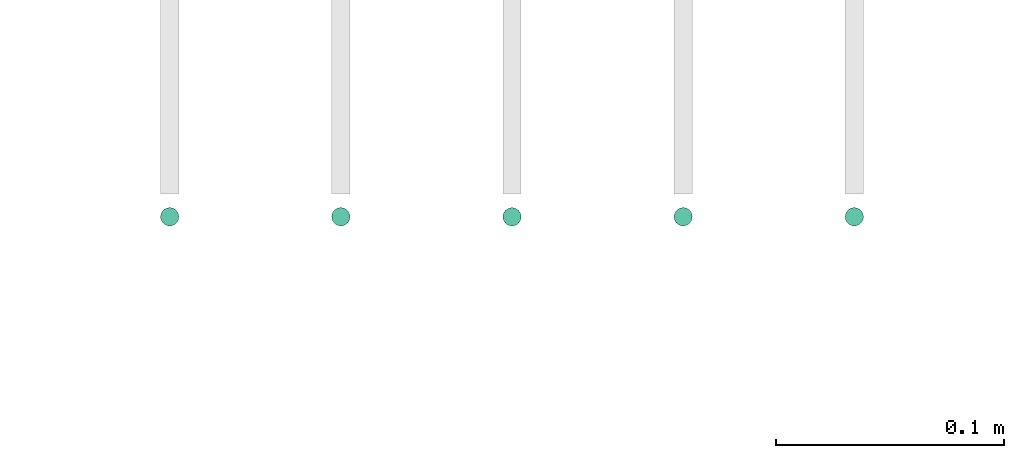
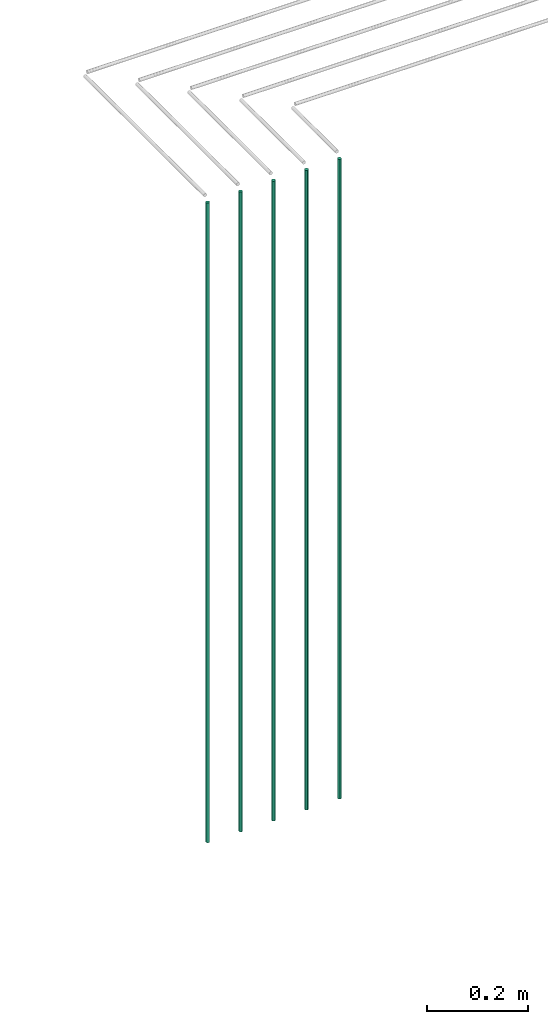
# One storey, part 17 of 89: 5 flow segments.
"""IFC2X3 building model written with IfcOpenShell, lengths in millimetres."""

from ifc_helpers import new_model, entity, si_unit, converted_unit, derived_unit, direction, frame, origin, origin_2d_with_axis, place, context, subcontext, project, spatial, circle, extrude, type_object, element, save


model = new_model("IFC2X3")

# Units and contexts
model_context = context("Model", 3, precision=0.01, world=origin(), true_north=direction((6.12303176911189e-17, 1.0)))
body_context = subcontext(model_context, "Body", "Model", "MODEL_VIEW")
ifc_project = project(units=[si_unit("LENGTHUNIT", "METRE", prefix="MILLI"), si_unit("AREAUNIT", "SQUARE_METRE"), si_unit("VOLUMEUNIT", "CUBIC_METRE"), converted_unit("PLANEANGLEUNIT", "DEGREE", entity("IfcRatioMeasure", 0.0174532925199433), si_unit("PLANEANGLEUNIT", "RADIAN"), dimensions=[0, 0, 0, 0, 0, 0, 0]), si_unit("MASSUNIT", "GRAM", prefix="KILO"), derived_unit("MASSDENSITYUNIT", [(si_unit("MASSUNIT", "GRAM", prefix="KILO"), 1), (si_unit("LENGTHUNIT", "METRE"), -3)]), derived_unit("MOMENTOFINERTIAUNIT", [(si_unit("LENGTHUNIT", "METRE"), 4)]), si_unit("TIMEUNIT", "SECOND"), si_unit("FREQUENCYUNIT", "HERTZ"), si_unit("THERMODYNAMICTEMPERATUREUNIT", "DEGREE_CELSIUS"), derived_unit("THERMALTRANSMITTANCEUNIT", [(si_unit("MASSUNIT", "GRAM", prefix="KILO"), 1), (si_unit("THERMODYNAMICTEMPERATUREUNIT", "KELVIN"), -1), (si_unit("TIMEUNIT", "SECOND"), -3)]), derived_unit("VOLUMETRICFLOWRATEUNIT", [(si_unit("LENGTHUNIT", "METRE"), 3), (si_unit("TIMEUNIT", "SECOND"), -1)]), derived_unit("MASSFLOWRATEUNIT", [(si_unit("MASSUNIT", "GRAM", prefix="KILO"), 1), (si_unit("TIMEUNIT", "SECOND"), -1)]), derived_unit("ROTATIONALFREQUENCYUNIT", [(si_unit("TIMEUNIT", "SECOND"), -1)]), si_unit("ELECTRICCURRENTUNIT", "AMPERE"), si_unit("ELECTRICVOLTAGEUNIT", "VOLT"), si_unit("POWERUNIT", "WATT"), si_unit("FORCEUNIT", "NEWTON", prefix="KILO"), si_unit("ILLUMINANCEUNIT", "LUX"), si_unit("LUMINOUSFLUXUNIT", "LUMEN"), si_unit("LUMINOUSINTENSITYUNIT", "CANDELA"), derived_unit("USERDEFINED", [(si_unit("MASSUNIT", "GRAM", prefix="KILO"), -1), (si_unit("LENGTHUNIT", "METRE"), -2), (si_unit("TIMEUNIT", "SECOND"), 3), (si_unit("LUMINOUSFLUXUNIT", "LUMEN"), 1)]), derived_unit("LINEARVELOCITYUNIT", [(si_unit("LENGTHUNIT", "METRE"), 1), (si_unit("TIMEUNIT", "SECOND"), -1)]), si_unit("PRESSUREUNIT", "PASCAL"), derived_unit("USERDEFINED", [(si_unit("LENGTHUNIT", "METRE"), -2), (si_unit("MASSUNIT", "GRAM", prefix="KILO"), 1), (si_unit("TIMEUNIT", "SECOND"), -2)]), derived_unit("LINEARFORCEUNIT", [(si_unit("MASSUNIT", "GRAM", prefix="KILO"), 1), (si_unit("LENGTHUNIT", "METRE"), 1), (si_unit("TIMEUNIT", "SECOND"), -2), (si_unit("LENGTHUNIT", "METRE"), -1)]), derived_unit("PLANARFORCEUNIT", [(si_unit("MASSUNIT", "GRAM", prefix="KILO"), 1), (si_unit("LENGTHUNIT", "METRE"), 1), (si_unit("TIMEUNIT", "SECOND"), -2), (si_unit("LENGTHUNIT", "METRE"), -2)])], contexts=[model_context])

# Site, building, storey
site_placement = place(None, frame((0.0, -0.00077364408347762, 0.0)))
site = spatial("IfcSite", under=ifc_project, at=site_placement, CompositionType="ELEMENT")
building_placement = place(site_placement, origin())
building = spatial("IfcBuilding", under=site, at=building_placement, CompositionType="ELEMENT")
storey_placement = place(building_placement, frame((0.0, 0.0, 24000.0)))
storey = spatial("IfcBuildingStorey", under=building, at=storey_placement, CompositionType="ELEMENT", Elevation=24000.0)

# Flow segments
pipe_segment_type = type_object("IfcPipeSegmentType", PredefinedType="NOTDEFINED")
for number, where in (
    (1, (63775.5981151137, 4939.4090624128, 1600.0)),
    (2, (63850.5981151137, 4939.4090624128, 1600.0)),
    (3, (63925.5981151137, 4939.4090624128, 1600.0)),
    (4, (64000.5981151137, 4939.4090624128, 1600.0)),
    (5, (64075.5981151137, 4939.4090624128, 1600.0)),
):
    element("IfcFlowSegment", number, at=place(storey_placement, frame(where)), inside=storey, type_object=pipe_segment_type, context=body_context, shape_type="SweptSolid", body=[
        extrude(circle(Radius=4.0, at=origin_2d_with_axis()), frame((5.59527223591499, 5.59527223591607, 0.0)), (0.0, 0.0, 1.0), 1540.0),
    ])

save(model, "model.ifc")
